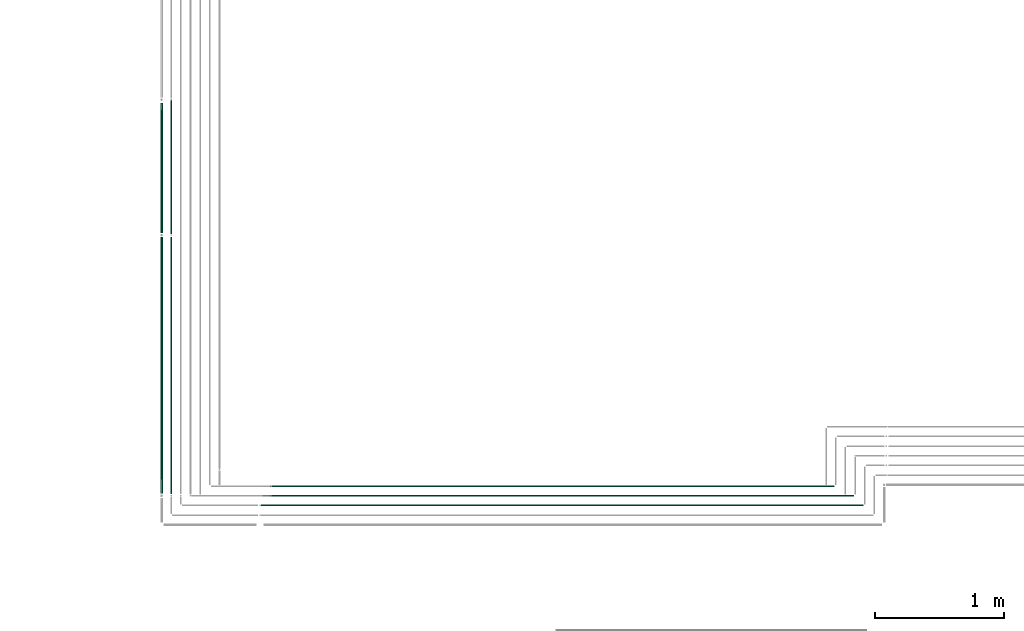
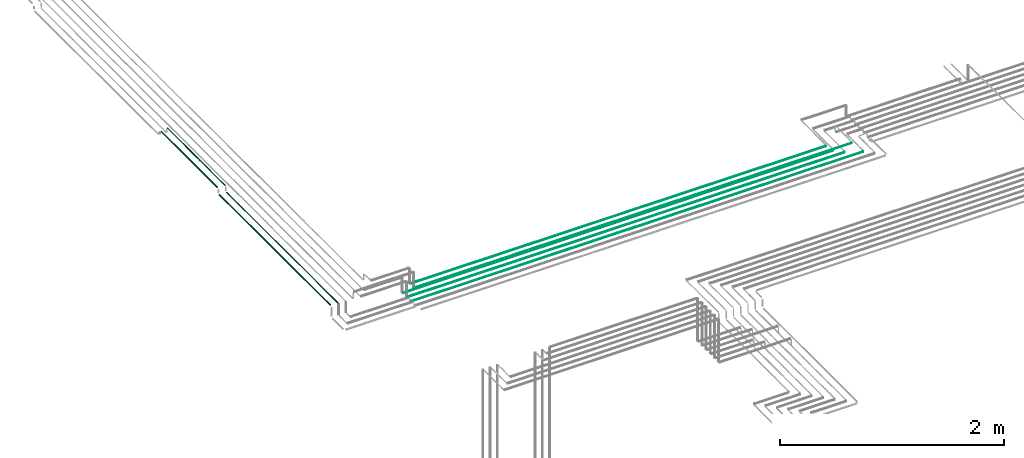
# One storey, part 27 of 89: 9 flow segments.
"""IFC2X3 building model written with IfcOpenShell, lengths in millimetres."""

from ifc_helpers import new_model, entity, si_unit, converted_unit, derived_unit, direction, frame, frame_2d, origin, origin_2d_with_axis, place, context, subcontext, project, spatial, circle, extrude, type_object, element, save


model = new_model("IFC2X3")

# Units and contexts
model_context = context("Model", 3, precision=0.01, world=origin(), true_north=direction((6.12303176911189e-17, 1.0)))
body_context = subcontext(model_context, "Body", "Model", "MODEL_VIEW")
ifc_project = project(units=[si_unit("LENGTHUNIT", "METRE", prefix="MILLI"), si_unit("AREAUNIT", "SQUARE_METRE"), si_unit("VOLUMEUNIT", "CUBIC_METRE"), converted_unit("PLANEANGLEUNIT", "DEGREE", entity("IfcRatioMeasure", 0.0174532925199433), si_unit("PLANEANGLEUNIT", "RADIAN"), dimensions=[0, 0, 0, 0, 0, 0, 0]), si_unit("MASSUNIT", "GRAM", prefix="KILO"), derived_unit("MASSDENSITYUNIT", [(si_unit("MASSUNIT", "GRAM", prefix="KILO"), 1), (si_unit("LENGTHUNIT", "METRE"), -3)]), derived_unit("MOMENTOFINERTIAUNIT", [(si_unit("LENGTHUNIT", "METRE"), 4)]), si_unit("TIMEUNIT", "SECOND"), si_unit("FREQUENCYUNIT", "HERTZ"), si_unit("THERMODYNAMICTEMPERATUREUNIT", "DEGREE_CELSIUS"), derived_unit("THERMALTRANSMITTANCEUNIT", [(si_unit("MASSUNIT", "GRAM", prefix="KILO"), 1), (si_unit("THERMODYNAMICTEMPERATUREUNIT", "KELVIN"), -1), (si_unit("TIMEUNIT", "SECOND"), -3)]), derived_unit("VOLUMETRICFLOWRATEUNIT", [(si_unit("LENGTHUNIT", "METRE"), 3), (si_unit("TIMEUNIT", "SECOND"), -1)]), derived_unit("MASSFLOWRATEUNIT", [(si_unit("MASSUNIT", "GRAM", prefix="KILO"), 1), (si_unit("TIMEUNIT", "SECOND"), -1)]), derived_unit("ROTATIONALFREQUENCYUNIT", [(si_unit("TIMEUNIT", "SECOND"), -1)]), si_unit("ELECTRICCURRENTUNIT", "AMPERE"), si_unit("ELECTRICVOLTAGEUNIT", "VOLT"), si_unit("POWERUNIT", "WATT"), si_unit("FORCEUNIT", "NEWTON", prefix="KILO"), si_unit("ILLUMINANCEUNIT", "LUX"), si_unit("LUMINOUSFLUXUNIT", "LUMEN"), si_unit("LUMINOUSINTENSITYUNIT", "CANDELA"), derived_unit("USERDEFINED", [(si_unit("MASSUNIT", "GRAM", prefix="KILO"), -1), (si_unit("LENGTHUNIT", "METRE"), -2), (si_unit("TIMEUNIT", "SECOND"), 3), (si_unit("LUMINOUSFLUXUNIT", "LUMEN"), 1)]), derived_unit("LINEARVELOCITYUNIT", [(si_unit("LENGTHUNIT", "METRE"), 1), (si_unit("TIMEUNIT", "SECOND"), -1)]), si_unit("PRESSUREUNIT", "PASCAL"), derived_unit("USERDEFINED", [(si_unit("LENGTHUNIT", "METRE"), -2), (si_unit("MASSUNIT", "GRAM", prefix="KILO"), 1), (si_unit("TIMEUNIT", "SECOND"), -2)]), derived_unit("LINEARFORCEUNIT", [(si_unit("MASSUNIT", "GRAM", prefix="KILO"), 1), (si_unit("LENGTHUNIT", "METRE"), 1), (si_unit("TIMEUNIT", "SECOND"), -2), (si_unit("LENGTHUNIT", "METRE"), -1)]), derived_unit("PLANARFORCEUNIT", [(si_unit("MASSUNIT", "GRAM", prefix="KILO"), 1), (si_unit("LENGTHUNIT", "METRE"), 1), (si_unit("TIMEUNIT", "SECOND"), -2), (si_unit("LENGTHUNIT", "METRE"), -2)])], contexts=[model_context])

# Site, building, storey
site_placement = place(None, frame((0.0, -0.00077364408347762, 0.0)))
site = spatial("IfcSite", under=ifc_project, at=site_placement, CompositionType="ELEMENT")
building_placement = place(site_placement, origin())
building = spatial("IfcBuilding", under=site, at=building_placement, CompositionType="ELEMENT")
storey_placement = place(building_placement, frame((0.0, 0.0, 24000.0)))
storey = spatial("IfcBuildingStorey", under=building, at=storey_placement, CompositionType="ELEMENT", Elevation=24000.0)

# Flow segments
pipe_segment_type = type_object("IfcPipeSegmentType", PredefinedType="NOTDEFINED")
flow_segment_1_placement = place(storey_placement, frame((65315.0302365425, 10194.4047277636, 2669.40472776408)))
element("IfcFlowSegment", 1, at=flow_segment_1_placement, inside=storey, type_object=pipe_segment_type, context=body_context, shape_type="SweptSolid", body=[
    extrude(circle(Radius=4.0, at=origin_2d_with_axis()), frame((0.0, 5.59527223601678, 5.59527223591499), z_axis=(1.0, 0.0, 0.0), x_axis=(0.0, -1.0, 0.0)), (0.0, 0.0, 1.0), 4669.68035740016),
])
flow_segment_2_placement = place(storey_placement, frame((65400.0302365425, 10269.4047277637, 2744.40472776409)))
element("IfcFlowSegment", 2, at=flow_segment_2_placement, inside=storey, type_object=pipe_segment_type, context=body_context, shape_type="SweptSolid", body=[
    extrude(circle(Radius=4.0, at=origin_2d_with_axis()), frame((0.0, 5.59527223591499, 5.59527223591499), z_axis=(1.0, 0.0, 0.0), x_axis=(0.0, 1.0, 0.0)), (0.0, 0.0, 1.0), 4509.68035740016),
])
flow_segment_3_placement = place(storey_placement, frame((65325.0302365425, 10269.4047277637, 2669.40472776407)))
element("IfcFlowSegment", 3, at=flow_segment_3_placement, inside=storey, type_object=pipe_segment_type, context=body_context, shape_type="SweptSolid", body=[
    extrude(circle(Radius=4.0, at=frame_2d((4.33146851719357e-12, 0.0), x_axis=(1.0, 0.0))), frame((0.0, 5.59527223591932, 5.59527223591499), z_axis=(1.0, 0.0, 0.0), x_axis=(0.0, 1.0, 0.0)), (0.0, 0.0, 1.0), 4509.68035740015),
])
flow_segment_4_placement = place(storey_placement, frame((65325.0302365425, 10344.4047277636, 2669.40472776407)))
element("IfcFlowSegment", 4, at=flow_segment_4_placement, inside=storey, type_object=pipe_segment_type, context=body_context, shape_type="SweptSolid", body=[
    extrude(circle(Radius=4.0, at=frame_2d((-7.36349647922907e-11, 0.0), x_axis=(1.0, 0.0))), frame((0.0, 5.59527223598863, 5.59527223591499), z_axis=(1.0, 0.0, 0.0), x_axis=(0.0, 1.0, 0.0)), (0.0, 0.0, 1.0), 4434.68035740017),
])
flow_segment_5_placement = place(storey_placement, frame((65400.0302365425, 10344.4047277637, 2744.40472776409)))
element("IfcFlowSegment", 5, at=flow_segment_5_placement, inside=storey, type_object=pipe_segment_type, context=body_context, shape_type="SweptSolid", body=[
    extrude(circle(Radius=4.0, at=frame_2d((-1.51601398101775e-11, 0.0), x_axis=(1.0, 0.0))), frame((0.0, 5.59527223593015, 5.59527223591499), z_axis=(1.0, 0.0, 0.0), x_axis=(0.0, 1.0, 0.0)), (0.0, 0.0, 1.0), 4285.0535064579),
])
flow_segment_6_placement = place(storey_placement, frame((64530.9898186752, 10293.0, 2840.90472776408)))
element("IfcFlowSegment", 6, at=flow_segment_6_placement, inside=storey, type_object=pipe_segment_type, context=body_context, shape_type="SweptSolid", body=[
    extrude(circle(Radius=7.5, at=frame_2d((8.66293703438714e-12, 0.0), x_axis=(1.0, 0.0))), frame((9.09527223592286, 0.0, 9.09527223591419), z_axis=(0.0, 1.0, 0.0), x_axis=(-1.0, 0.0, 0.0)), (0.0, 0.0, 1.0), 1986.15512441972),
])
flow_segment_7_placement = place(storey_placement, frame((64530.9898186752, 12315.1551244193, 2900.90472776414)))
element("IfcFlowSegment", 7, at=flow_segment_7_placement, inside=storey, type_object=pipe_segment_type, context=body_context, shape_type="SweptSolid", body=[
    extrude(circle(Radius=7.5, at=frame_2d((8.66293703438714e-12, 0.0), x_axis=(1.0, 0.0))), frame((9.09527223593152, 0.0, 9.09527223591419), z_axis=(0.0, 1.0, 0.0), x_axis=(-1.0, 0.0, 0.0)), (0.0, 0.0, 1.0), 1003.00000000002),
])
flow_segment_8_placement = place(storey_placement, frame((64609.4898186752, 10292.0, 2844.40472776416)))
element("IfcFlowSegment", 8, at=flow_segment_8_placement, inside=storey, type_object=pipe_segment_type, context=body_context, shape_type="SweptSolid", body=[
    extrude(circle(Radius=4.0, at=origin_2d_with_axis()), frame((5.59527223591499, 0.0, 5.59527223591499), z_axis=(0.0, 1.0, 0.0), x_axis=(1.0, 0.0, 0.0)), (0.0, 0.0, 1.0), 1988.1551244197),
])
flow_segment_9_placement = place(storey_placement, frame((64609.4898186752, 12307.1551244193, 2904.40472776414)))
element("IfcFlowSegment", 9, at=flow_segment_9_placement, inside=storey, type_object=pipe_segment_type, context=body_context, shape_type="SweptSolid", body=[
    extrude(circle(Radius=4.0, at=origin_2d_with_axis()), frame((5.59527223591499, 0.0, 5.59527223591499), z_axis=(0.0, 1.0, 0.0), x_axis=(-1.0, 0.0, 0.0)), (0.0, 0.0, 1.0), 1030.00000000003),
])

save(model, "model.ifc")
